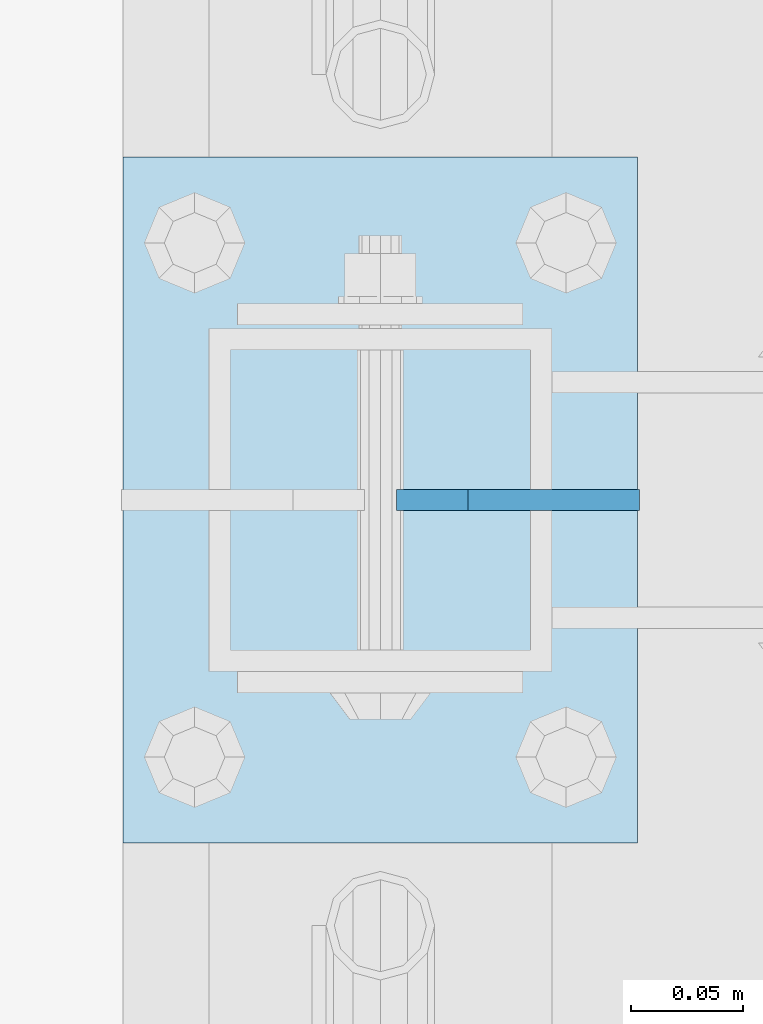
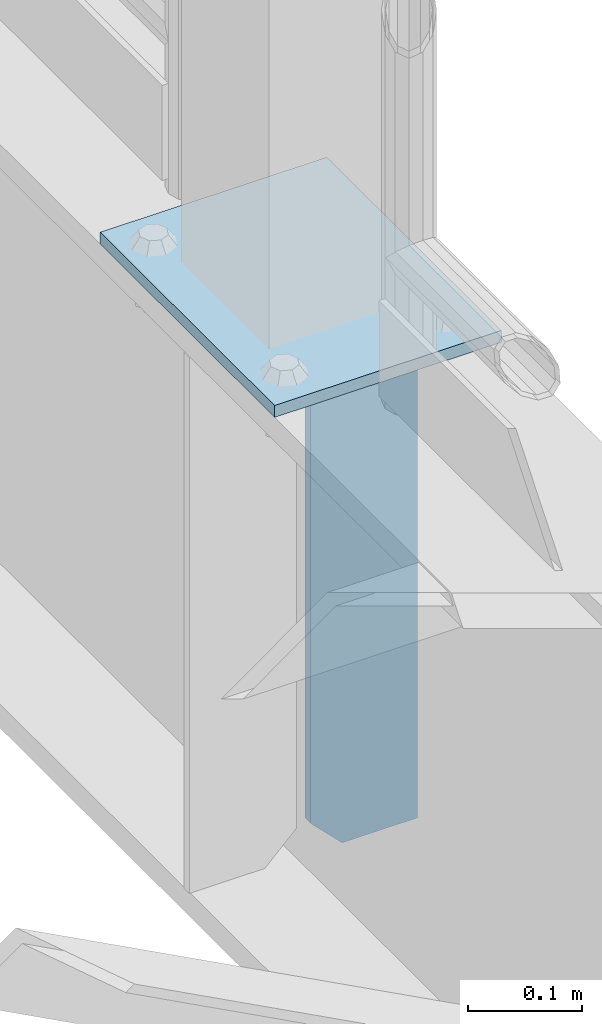
# One storey, part 1670 of 1876: 2 plates, 2 elements without a shape of their own.
"""IFC2X3 building model written with IfcOpenShell, lengths in millimetres."""

from ifc_helpers import new_model, si_unit, frame, origin_with_axes, place, context, subcontext, project, spatial, faceted_brep, material, type_object, element, aggregate, save


model = new_model("IFC2X3")

# Units and contexts
model_context = context("Model", 3, precision=1e-05, world=origin_with_axes())
body_context = subcontext(model_context, "Body", "Model", "MODEL_VIEW")
ifc_project = project(units=[si_unit("LENGTHUNIT", "METRE", prefix="MILLI"), si_unit("AREAUNIT", "SQUARE_METRE"), si_unit("VOLUMEUNIT", "CUBIC_METRE"), si_unit("MASSUNIT", "GRAM", prefix="KILO"), si_unit("TIMEUNIT", "SECOND"), si_unit("PLANEANGLEUNIT", "RADIAN"), si_unit("SOLIDANGLEUNIT", "STERADIAN"), si_unit("THERMODYNAMICTEMPERATUREUNIT", "DEGREE_CELSIUS"), si_unit("LUMINOUSINTENSITYUNIT", "LUMEN")], contexts=[model_context])

# Site, building, storey
site_placement = place(None, origin_with_axes())
site = spatial("IfcSite", under=ifc_project, at=site_placement, CompositionType="ELEMENT")
building_placement = place(site_placement, origin_with_axes())
building = spatial("IfcBuilding", under=site, at=building_placement, Name="Undefined", CompositionType="ELEMENT")
storey_placement = place(building_placement, origin_with_axes())
storey = spatial("IfcBuildingStorey", under=building, at=storey_placement, Name="Undefined", CompositionType="ELEMENT", Elevation=0.0)

# Assembly, plate
assembly_1_placement = place(storey_placement, origin_with_axes())
assembly_1 = element("IfcElementAssembly", 1, at=assembly_1_placement, inside=storey, Name="BEAM", AssemblyPlace="NOTDEFINED", PredefinedType="RIGID_FRAME")
ifc_material = material(Name="STEEL/A36")
plate_type_1 = type_object("IfcPlateType", PredefinedType="NOTDEFINED")
plate_1_placement = place(assembly_1_placement, frame((7735.09375, -508.0, 7556.5), z_axis=(0.0, 0.0, 1.0), x_axis=(-1.0, 0.0, 0.0)))
plate_1 = element("IfcPlate", 2, at=plate_1_placement, type_object=plate_type_1, material=ifc_material, Name="PLATE", context=body_context, shape_type="Brep", body=[
    faceted_brep([(0.0, -4.76249999999982, 0.0), (0.0, -4.76249999999982, 571.5), (0.0, 4.76249999999982, 571.5), (0.0, 4.76249999999982, 0.0), (76.1999969482422, -4.76249999999982, 571.5), (76.1999969482422, 4.76249999999982, 571.5), (107.949996948242, -4.76249999999982, 539.75), (107.949996948242, 4.76249999999982, 539.75), (107.949996948242, -4.76249999999982, 31.75), (107.949996948242, 4.76249999999982, 31.75), (76.1999969482422, -4.76250000000073, 0.0), (76.1999969482422, 4.76250000000073, 0.0)], [[[0, 1, 2, 3]], [[1, 4, 5, 2]], [[4, 6, 7, 5]], [[6, 8, 9, 7]], [[8, 10, 11, 9]], [[10, 0, 3, 11]], [[5, 7, 9, 11, 3, 2]], [[10, 8, 6, 4, 1, 0]]]),
])
aggregate(assembly_1, [plate_1])

assembly_2_placement = place(storey_placement, origin_with_axes())
assembly_2 = element("IfcElementAssembly", 3, at=assembly_2_placement, inside=storey, Name="BEAM", AssemblyPlace="NOTDEFINED", PredefinedType="RIGID_FRAME")
plate_type_2 = type_object("IfcPlateType", PredefinedType="NOTDEFINED")
plate_2_placement = place(assembly_2_placement, frame((7505.7, -660.400000000001, 8159.75), z_axis=(0.0, 1.0, 0.0), x_axis=(1.0, 0.0, 0.0)))
plate_2 = element("IfcPlate", 4, at=plate_2_placement, type_object=plate_type_2, material=ifc_material, Name="PLATE", context=body_context, shape_type="Brep", body=[
    faceted_brep([(0.0, -6.35000000000036, 0.0), (0.0, -6.35000000000036, 304.799987792969), (0.0, 6.35000000000036, 304.799987792969), (0.0, 6.35000000000036, 0.0), (228.600006103516, -6.34999999999854, 304.799987792969), (228.600006103516, 6.34999999999854, 304.799987792969), (228.600006103516, -6.34999999999854, 0.0), (228.600006103516, 6.34999999999854, 0.0)], [[[0, 1, 2, 3]], [[1, 4, 5, 2]], [[4, 6, 7, 5]], [[6, 0, 3, 7]], [[5, 7, 3, 2]], [[6, 4, 1, 0]]]),
])
aggregate(assembly_2, [plate_2])

save(model, "model.ifc")
